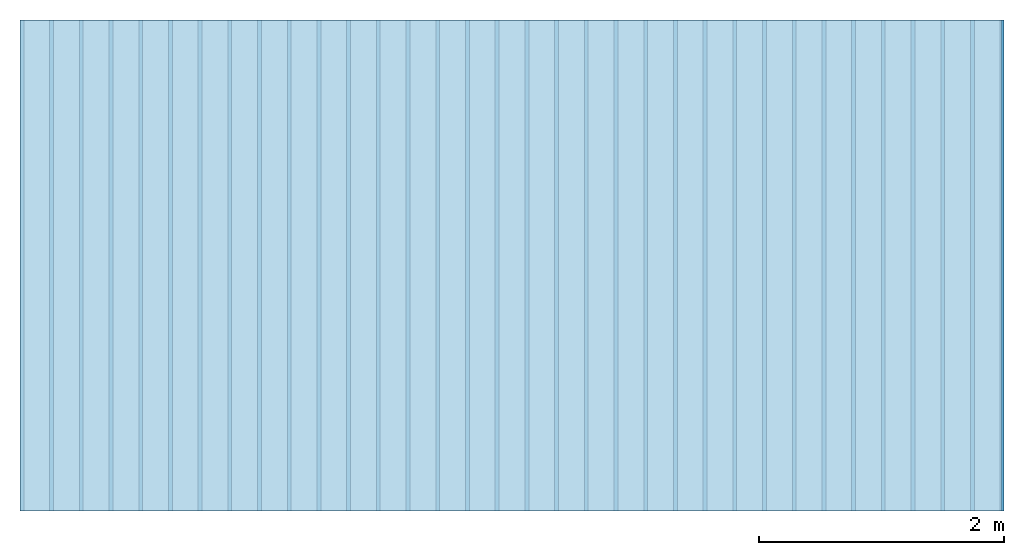
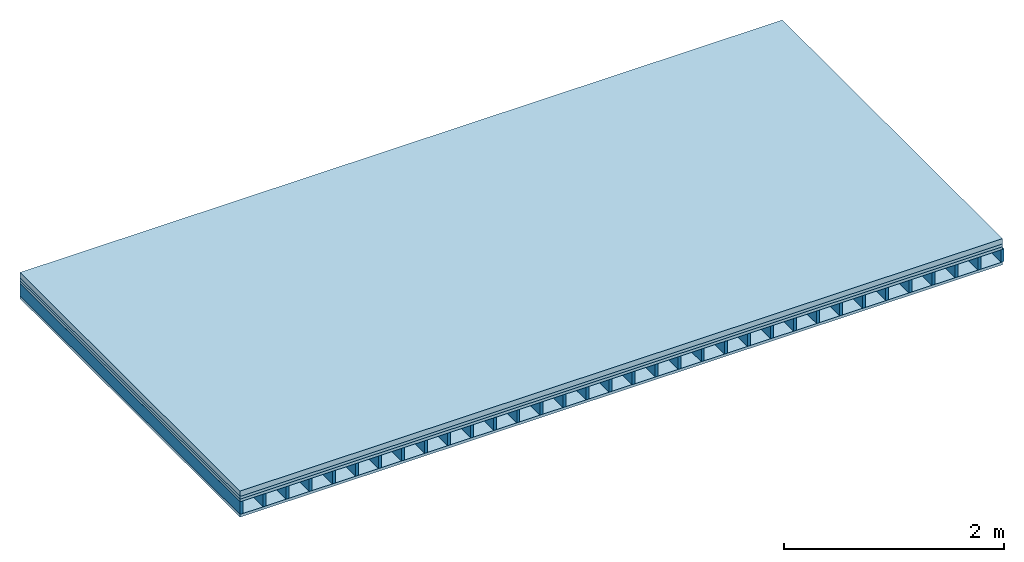
# One storey: 4 plates, 1 member, 1 element without a shape of its own.
"""IFC4 building model written with IfcOpenShell, lengths in metres."""

from ifc_helpers import new_model, si_unit, derived_unit, direction, frame, frame_2d, origin, origin_with_axes, place, context, project, spatial, rectangle, extrude, material, layer, layer_set, type_object, element, aggregate, save


model = new_model("IFC4")

# Units and contexts
plan_context = context("Plan", 3, precision=1e-05, world=origin(), true_north=direction((0.0, 1.0)))
model_context = context("Model", 3, precision=1e-05, world=origin(), true_north=direction((0.0, 1.0)))
ifc_project = project(units=[si_unit("LENGTHUNIT", "METRE"), derived_unit("SOUNDPRESSUREUNIT", [(si_unit("PRESSUREUNIT", "PASCAL", prefix="MICRO"), 0)]), si_unit("ENERGYUNIT", "JOULE", prefix="MEGA"), si_unit("MASSUNIT", "GRAM", prefix="KILO"), derived_unit("THERMALTRANSMITTANCEUNIT", [(si_unit("POWERUNIT", "WATT"), 1), (si_unit("AREAUNIT", "SQUARE_METRE"), -1), (si_unit("THERMODYNAMICTEMPERATUREUNIT", "KELVIN"), -1)]), derived_unit("AREADENSITYUNIT", [(si_unit("MASSUNIT", "GRAM", prefix="KILO"), 1), (si_unit("AREAUNIT", "SQUARE_METRE"), -1)]), derived_unit("USERDEFINED", [(si_unit("ENERGYUNIT", "JOULE", prefix="MEGA"), 1), (si_unit("AREAUNIT", "SQUARE_METRE"), -1)])], contexts=[plan_context, model_context])

# Site, building, storey
site = spatial("IfcSite", under=ifc_project)
building_placement = place(None, origin())
building = spatial("IfcBuilding", under=site, at=building_placement)
storey_placement = place(building_placement, origin())
storey = spatial("IfcBuildingStorey", under=building, at=storey_placement)

# Slab, member, plates
ifc_material_1 = material(Name="Cement screed", Category="04.006")
ifc_layer_1 = layer(ifc_material_1, 0.06, Name="On-material")
ifc_material_2 = material()
ifc_layer_2 = layer(ifc_material_2, 0.03, Name="Impact sound insulation")
ifc_material_3 = material(Name="Element above")
ifc_layer_3 = layer(ifc_material_3, 0.0305, Name="Sub-floor")
ifc_material_4 = material(Name="Rigid")
ifc_layer_4 = layer(ifc_material_4, 0.0, Name="Bond")
ifc_layer_5 = layer(None, 0.139, Name="Supporting structure")
ifc_material_5 = material(Name="Rigid, of the art")
ifc_layer_6 = layer(ifc_material_5, 0.0, Name="Bond")
ifc_material_6 = material(Name="Element below")
ifc_layer_7 = layer(ifc_material_6, 0.0305, Name="Lower layer 1")
ifc_layer_set = layer_set([ifc_layer_1, ifc_layer_2, ifc_layer_3, ifc_layer_4, ifc_layer_5, ifc_layer_6, ifc_layer_7])
slab_type = type_object("IfcSlabType", Name="A2277", PredefinedType="NOTDEFINED", material=ifc_layer_set)
slab_placement = place(None, frame((0.0, 0.0, 0.0), z_axis=(0.0, 0.0, -1.0), x_axis=(1.0, 0.0, 0.0)))
slab = element("IfcSlab", 1, at=slab_placement, inside=storey, type_object=slab_type, material=ifc_layer_set, Name="Slab #1")
ifc_material_7 = material(Name="Floor element EB")
member_placement = place(slab_placement, origin())
member = element("IfcMember", 2, at=member_placement, material=ifc_material_7, Name="Supporting structure", context=plan_context, shape_type="SweptSolid", body=[
    extrude(rectangle(XDim=0.031, YDim=0.139, at=frame_2d((0.0155, 0.0695), x_axis=(1.0, 0.0))), frame((0.0, 4.0, 0.1205), z_axis=(0.0, -1.0, 0.0), x_axis=(1.0, 0.0, 0.0)), (0.0, 0.0, 1.0), 4.0),
    extrude(rectangle(XDim=0.031, YDim=0.139, at=frame_2d((0.0155, 0.0695), x_axis=(1.0, 0.0))), frame((0.242, 4.0, 0.1205), z_axis=(0.0, -1.0, 0.0), x_axis=(1.0, 0.0, 0.0)), (0.0, 0.0, 1.0), 4.0),
    extrude(rectangle(XDim=0.031, YDim=0.139, at=frame_2d((0.0155, 0.0695), x_axis=(1.0, 0.0))), frame((0.484, 4.0, 0.1205), z_axis=(0.0, -1.0, 0.0), x_axis=(1.0, 0.0, 0.0)), (0.0, 0.0, 1.0), 4.0),
    extrude(rectangle(XDim=0.031, YDim=0.139, at=frame_2d((0.0155, 0.0695), x_axis=(1.0, 0.0))), frame((0.726, 4.0, 0.1205), z_axis=(0.0, -1.0, 0.0), x_axis=(1.0, 0.0, 0.0)), (0.0, 0.0, 1.0), 4.0),
    extrude(rectangle(XDim=0.031, YDim=0.139, at=frame_2d((0.0155, 0.0695), x_axis=(1.0, 0.0))), frame((0.968, 4.0, 0.1205), z_axis=(0.0, -1.0, 0.0), x_axis=(1.0, 0.0, 0.0)), (0.0, 0.0, 1.0), 4.0),
    extrude(rectangle(XDim=0.031, YDim=0.139, at=frame_2d((0.0155, 0.0695), x_axis=(1.0, 0.0))), frame((1.21, 4.0, 0.1205), z_axis=(0.0, -1.0, 0.0), x_axis=(1.0, 0.0, 0.0)), (0.0, 0.0, 1.0), 4.0),
    extrude(rectangle(XDim=0.031, YDim=0.139, at=frame_2d((0.0155, 0.0695), x_axis=(1.0, 0.0))), frame((1.452, 4.0, 0.1205), z_axis=(0.0, -1.0, 0.0), x_axis=(1.0, 0.0, 0.0)), (0.0, 0.0, 1.0), 4.0),
    extrude(rectangle(XDim=0.031, YDim=0.139, at=frame_2d((0.0155, 0.0695), x_axis=(1.0, 0.0))), frame((1.694, 4.0, 0.1205), z_axis=(0.0, -1.0, 0.0), x_axis=(1.0, 0.0, 0.0)), (0.0, 0.0, 1.0), 4.0),
    extrude(rectangle(XDim=0.031, YDim=0.139, at=frame_2d((0.0155, 0.0695), x_axis=(1.0, 0.0))), frame((1.936, 4.0, 0.1205), z_axis=(0.0, -1.0, 0.0), x_axis=(1.0, 0.0, 0.0)), (0.0, 0.0, 1.0), 4.0),
    extrude(rectangle(XDim=0.031, YDim=0.139, at=frame_2d((0.0155, 0.0695), x_axis=(1.0, 0.0))), frame((2.178, 4.0, 0.1205), z_axis=(0.0, -1.0, 0.0), x_axis=(1.0, 0.0, 0.0)), (0.0, 0.0, 1.0), 4.0),
    extrude(rectangle(XDim=0.031, YDim=0.139, at=frame_2d((0.0155, 0.0695), x_axis=(1.0, 0.0))), frame((2.42, 4.0, 0.1205), z_axis=(0.0, -1.0, 0.0), x_axis=(1.0, 0.0, 0.0)), (0.0, 0.0, 1.0), 4.0),
    extrude(rectangle(XDim=0.031, YDim=0.139, at=frame_2d((0.0155, 0.0695), x_axis=(1.0, 0.0))), frame((2.662, 4.0, 0.1205), z_axis=(0.0, -1.0, 0.0), x_axis=(1.0, 0.0, 0.0)), (0.0, 0.0, 1.0), 4.0),
    extrude(rectangle(XDim=0.031, YDim=0.139, at=frame_2d((0.0155, 0.0695), x_axis=(1.0, 0.0))), frame((2.904, 4.0, 0.1205), z_axis=(0.0, -1.0, 0.0), x_axis=(1.0, 0.0, 0.0)), (0.0, 0.0, 1.0), 4.0),
    extrude(rectangle(XDim=0.031, YDim=0.139, at=frame_2d((0.0155, 0.0695), x_axis=(1.0, 0.0))), frame((3.146, 4.0, 0.1205), z_axis=(0.0, -1.0, 0.0), x_axis=(1.0, 0.0, 0.0)), (0.0, 0.0, 1.0), 4.0),
    extrude(rectangle(XDim=0.031, YDim=0.139, at=frame_2d((0.0155, 0.0695), x_axis=(1.0, 0.0))), frame((3.388, 4.0, 0.1205), z_axis=(0.0, -1.0, 0.0), x_axis=(1.0, 0.0, 0.0)), (0.0, 0.0, 1.0), 4.0),
    extrude(rectangle(XDim=0.031, YDim=0.139, at=frame_2d((0.0155, 0.0695), x_axis=(1.0, 0.0))), frame((3.63, 4.0, 0.1205), z_axis=(0.0, -1.0, 0.0), x_axis=(1.0, 0.0, 0.0)), (0.0, 0.0, 1.0), 4.0),
    extrude(rectangle(XDim=0.031, YDim=0.139, at=frame_2d((0.0155, 0.0695), x_axis=(1.0, 0.0))), frame((3.872, 4.0, 0.1205), z_axis=(0.0, -1.0, 0.0), x_axis=(1.0, 0.0, 0.0)), (0.0, 0.0, 1.0), 4.0),
    extrude(rectangle(XDim=0.031, YDim=0.139, at=frame_2d((0.0155, 0.0695), x_axis=(1.0, 0.0))), frame((4.114, 4.0, 0.1205), z_axis=(0.0, -1.0, 0.0), x_axis=(1.0, 0.0, 0.0)), (0.0, 0.0, 1.0), 4.0),
    extrude(rectangle(XDim=0.031, YDim=0.139, at=frame_2d((0.0155, 0.0695), x_axis=(1.0, 0.0))), frame((4.356, 4.0, 0.1205), z_axis=(0.0, -1.0, 0.0), x_axis=(1.0, 0.0, 0.0)), (0.0, 0.0, 1.0), 4.0),
    extrude(rectangle(XDim=0.031, YDim=0.139, at=frame_2d((0.0155, 0.0695), x_axis=(1.0, 0.0))), frame((4.598, 4.0, 0.1205), z_axis=(0.0, -1.0, 0.0), x_axis=(1.0, 0.0, 0.0)), (0.0, 0.0, 1.0), 4.0),
    extrude(rectangle(XDim=0.031, YDim=0.139, at=frame_2d((0.0155, 0.0695), x_axis=(1.0, 0.0))), frame((4.84, 4.0, 0.1205), z_axis=(0.0, -1.0, 0.0), x_axis=(1.0, 0.0, 0.0)), (0.0, 0.0, 1.0), 4.0),
    extrude(rectangle(XDim=0.031, YDim=0.139, at=frame_2d((0.0155, 0.0695), x_axis=(1.0, 0.0))), frame((5.082, 4.0, 0.1205), z_axis=(0.0, -1.0, 0.0), x_axis=(1.0, 0.0, 0.0)), (0.0, 0.0, 1.0), 4.0),
    extrude(rectangle(XDim=0.031, YDim=0.139, at=frame_2d((0.0155, 0.0695), x_axis=(1.0, 0.0))), frame((5.324, 4.0, 0.1205), z_axis=(0.0, -1.0, 0.0), x_axis=(1.0, 0.0, 0.0)), (0.0, 0.0, 1.0), 4.0),
    extrude(rectangle(XDim=0.031, YDim=0.139, at=frame_2d((0.0155, 0.0695), x_axis=(1.0, 0.0))), frame((5.566, 4.0, 0.1205), z_axis=(0.0, -1.0, 0.0), x_axis=(1.0, 0.0, 0.0)), (0.0, 0.0, 1.0), 4.0),
    extrude(rectangle(XDim=0.031, YDim=0.139, at=frame_2d((0.0155, 0.0695), x_axis=(1.0, 0.0))), frame((5.808, 4.0, 0.1205), z_axis=(0.0, -1.0, 0.0), x_axis=(1.0, 0.0, 0.0)), (0.0, 0.0, 1.0), 4.0),
    extrude(rectangle(XDim=0.031, YDim=0.139, at=frame_2d((0.0155, 0.0695), x_axis=(1.0, 0.0))), frame((6.05, 4.0, 0.1205), z_axis=(0.0, -1.0, 0.0), x_axis=(1.0, 0.0, 0.0)), (0.0, 0.0, 1.0), 4.0),
    extrude(rectangle(XDim=0.031, YDim=0.139, at=frame_2d((0.0155, 0.0695), x_axis=(1.0, 0.0))), frame((6.292, 4.0, 0.1205), z_axis=(0.0, -1.0, 0.0), x_axis=(1.0, 0.0, 0.0)), (0.0, 0.0, 1.0), 4.0),
    extrude(rectangle(XDim=0.031, YDim=0.139, at=frame_2d((0.0155, 0.0695), x_axis=(1.0, 0.0))), frame((6.534, 4.0, 0.1205), z_axis=(0.0, -1.0, 0.0), x_axis=(1.0, 0.0, 0.0)), (0.0, 0.0, 1.0), 4.0),
    extrude(rectangle(XDim=0.031, YDim=0.139, at=frame_2d((0.0155, 0.0695), x_axis=(1.0, 0.0))), frame((6.776, 4.0, 0.1205), z_axis=(0.0, -1.0, 0.0), x_axis=(1.0, 0.0, 0.0)), (0.0, 0.0, 1.0), 4.0),
    extrude(rectangle(XDim=0.031, YDim=0.139, at=frame_2d((0.0155, 0.0695), x_axis=(1.0, 0.0))), frame((7.018, 4.0, 0.1205), z_axis=(0.0, -1.0, 0.0), x_axis=(1.0, 0.0, 0.0)), (0.0, 0.0, 1.0), 4.0),
    extrude(rectangle(XDim=0.031, YDim=0.139, at=frame_2d((0.0155, 0.0695), x_axis=(1.0, 0.0))), frame((7.26, 4.0, 0.1205), z_axis=(0.0, -1.0, 0.0), x_axis=(1.0, 0.0, 0.0)), (0.0, 0.0, 1.0), 4.0),
    extrude(rectangle(XDim=0.031, YDim=0.139, at=frame_2d((0.0155, 0.0695), x_axis=(1.0, 0.0))), frame((7.502, 4.0, 0.1205), z_axis=(0.0, -1.0, 0.0), x_axis=(1.0, 0.0, 0.0)), (0.0, 0.0, 1.0), 4.0),
    extrude(rectangle(XDim=0.031, YDim=0.139, at=frame_2d((0.0155, 0.0695), x_axis=(1.0, 0.0))), frame((7.744, 4.0, 0.1205), z_axis=(0.0, -1.0, 0.0), x_axis=(1.0, 0.0, 0.0)), (0.0, 0.0, 1.0), 4.0),
    extrude(rectangle(XDim=0.031, YDim=0.139, at=frame_2d((0.0155, 0.0695), x_axis=(1.0, 0.0))), frame((7.986, 4.0, 0.1205), z_axis=(0.0, -1.0, 0.0), x_axis=(1.0, 0.0, 0.0)), (0.0, 0.0, 1.0), 4.0),
])
plate_1_placement = place(slab_placement, origin())
plate_1 = element("IfcPlate", 3, at=plate_1_placement, material=ifc_material_1, Name="On-material", context=plan_context, shape_type="SweptSolid", body=[
    extrude(rectangle(XDim=8.0, YDim=4.0, at=frame_2d((4.0, 2.0), x_axis=(1.0, 0.0))), origin_with_axes(), (0.0, 0.0, 1.0), 0.06),
])
plate_2_placement = place(slab_placement, origin())
plate_2 = element("IfcPlate", 4, at=plate_2_placement, material=ifc_material_2, Name="Impact sound insulation", context=plan_context, shape_type="SweptSolid", body=[
    extrude(rectangle(XDim=8.0, YDim=4.0, at=frame_2d((4.0, 2.0), x_axis=(1.0, 0.0))), frame((0.0, 0.0, 0.06), z_axis=(0.0, 0.0, 1.0), x_axis=(1.0, 0.0, 0.0)), (0.0, 0.0, 1.0), 0.03),
])
plate_3_placement = place(slab_placement, origin())
plate_3 = element("IfcPlate", 5, at=plate_3_placement, material=ifc_material_3, Name="Sub-floor", context=plan_context, shape_type="SweptSolid", body=[
    extrude(rectangle(XDim=8.0, YDim=4.0, at=frame_2d((4.0, 2.0), x_axis=(1.0, 0.0))), frame((0.0, 0.0, 0.09), z_axis=(0.0, 0.0, 1.0), x_axis=(1.0, 0.0, 0.0)), (0.0, 0.0, 1.0), 0.0305),
])
plate_4_placement = place(slab_placement, origin())
plate_4 = element("IfcPlate", 6, at=plate_4_placement, material=ifc_material_6, Name="Lower layer 1", context=plan_context, shape_type="SweptSolid", body=[
    extrude(rectangle(XDim=8.0, YDim=4.0, at=frame_2d((4.0, 2.0), x_axis=(1.0, 0.0))), frame((0.0, 0.0, 0.2595), z_axis=(0.0, 0.0, 1.0), x_axis=(1.0, 0.0, 0.0)), (0.0, 0.0, 1.0), 0.0305),
])
aggregate(slab, [plate_1, plate_2, plate_3, member, plate_4])

save(model, "model.ifc")
